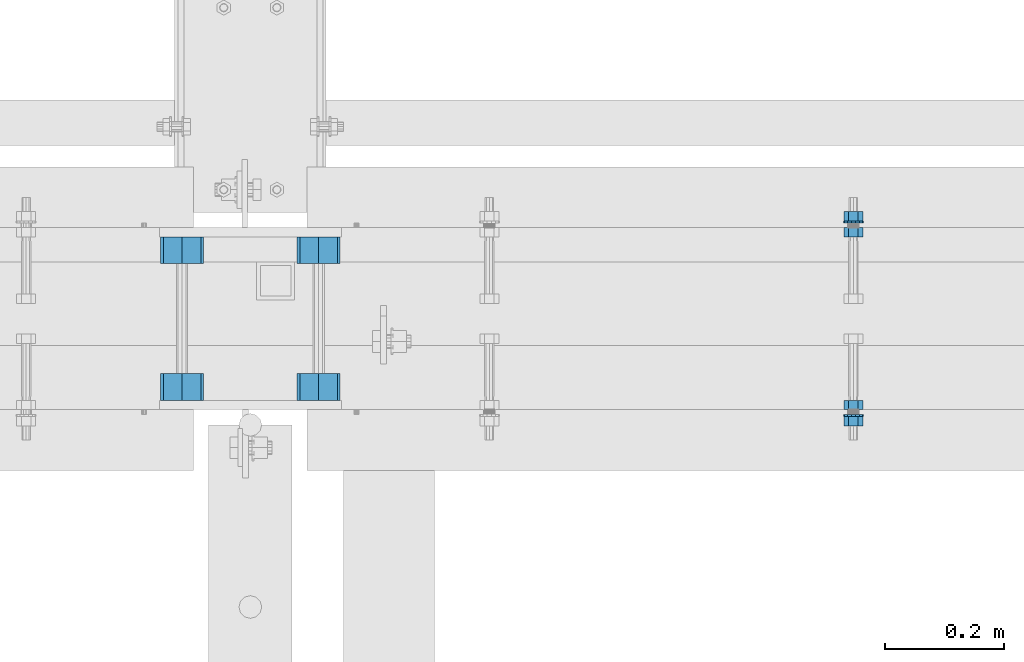
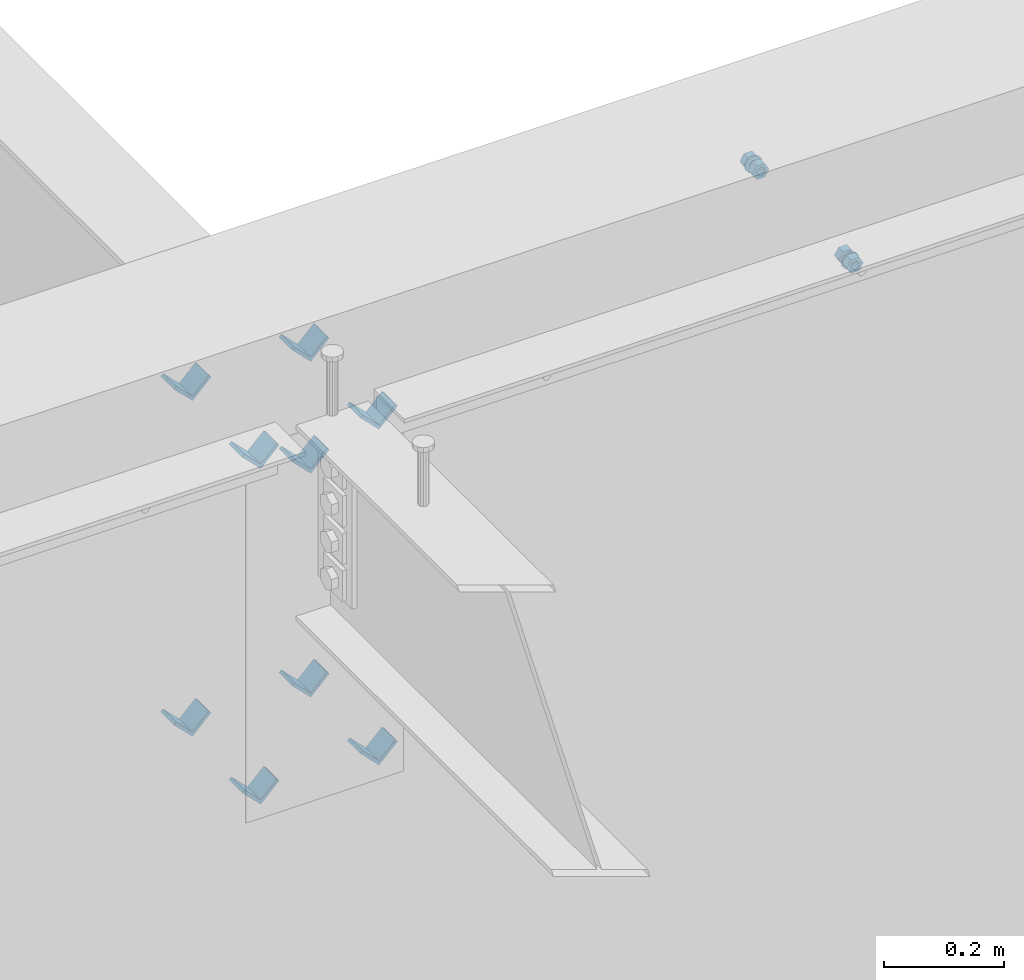
# One storey, part 610 of 975: 15 beams.
"""IFC2X3 building model written with IfcOpenShell, lengths in millimetres."""

from ifc_helpers import new_model, si_unit, frame, origin_with_axes, place, context, subcontext, project, spatial, faceted_brep, material, type_object, element, save


model = new_model("IFC2X3")

# Units and contexts
model_context = context("Model", 3, precision=1e-05, world=origin_with_axes())
body_context = subcontext(model_context, "Body", "Model", "MODEL_VIEW")
ifc_project = project(units=[si_unit("LENGTHUNIT", "METRE", prefix="MILLI"), si_unit("AREAUNIT", "SQUARE_METRE"), si_unit("VOLUMEUNIT", "CUBIC_METRE"), si_unit("MASSUNIT", "GRAM", prefix="KILO"), si_unit("TIMEUNIT", "SECOND"), si_unit("PLANEANGLEUNIT", "RADIAN"), si_unit("SOLIDANGLEUNIT", "STERADIAN"), si_unit("THERMODYNAMICTEMPERATUREUNIT", "DEGREE_CELSIUS"), si_unit("LUMINOUSINTENSITYUNIT", "LUMEN")], contexts=[model_context])

# Site, building, storey
site_placement = place(None, origin_with_axes())
site = spatial("IfcSite", under=ifc_project, at=site_placement, CompositionType="ELEMENT")
building_placement = place(site_placement, origin_with_axes())
building = spatial("IfcBuilding", under=site, at=building_placement, Name="Undefined", CompositionType="ELEMENT")
storey_placement = place(building_placement, origin_with_axes())
storey = spatial("IfcBuildingStorey", under=building, at=storey_placement, Name="Undefined", CompositionType="ELEMENT", Elevation=0.0)

# Beams
ifc_material = material(Name="STEEL/A36")
beam_type_1 = type_object("IfcBeamType", Name="L2X2X1/4", PredefinedType="NOTDEFINED")
for number, where, z_axis, x_axis, name in (
    (1, (8343.90041900943, 20688.3662709101, 3645.66996517217), (-0.707106781186557, 0.0, 0.707106781186538), (0.0, 1.0, 0.0), "ANGLE"),
    (2, (8115.3004190083, 20459.6337290899, 3188.4699651707), (-0.707106781186557, 0.0, 0.707106781186538), (0.0, 1.0, 0.0), "ANGLE"),
    (3, (8115.30041900943, 20459.6337290899, 3874.26996517217), (-0.707106781186557, 0.0, 0.707106781186538), (0.0, 1.0, 0.0), "ANGLE"),
    (4, (8343.90041900831, 20459.6337290899, 3188.4699651707), (-0.707106781186557, 0.0, 0.707106781186538), (0.0, 1.0, 0.0), "ANGLE"),
    (5, (8343.90041900943, 20459.6337290899, 3874.26996517217), (-0.707106781186557, 0.0, 0.707106781186538), (0.0, 1.0, 0.0), "ANGLE"),
    (6, (8115.3004190083, 20688.3662709101, 3188.4699651707), (-0.707106781186557, 0.0, 0.707106781186538), (0.0, 1.0, 0.0), "ANGLE"),
    (7, (8115.30041900943, 20688.3662709101, 3874.26996517217), (-0.707106781186557, 0.0, 0.707106781186538), (0.0, 1.0, 0.0), "ANGLE"),
    (8, (8343.90041900831, 20688.3662709101, 3188.4699651707), (-0.707106781186557, 0.0, 0.707106781186538), (0.0, 1.0, 0.0), "ANGLE"),
    (9, (8343.90041900943, 20688.3662709101, 3874.26996517217), (-0.707106781186557, 0.0, 0.707106781186538), (0.0, 1.0, 0.0), "ANGLE"),
):
    element("IfcBeam", number, at=place(storey_placement, frame(where, z_axis=z_axis, x_axis=x_axis)), inside=storey, type_object=beam_type_1, material=ifc_material, Name=name, ObjectType="L2X2X1/4", context=body_context, shape_type="Brep", body=[
        faceted_brep([(0.0, 25.3999999999724, -25.4000000000342), (0.0, 25.400000000016, 25.4000000000196), (44.4499999999971, 25.4000000000033, 25.4000000000051), (44.4499999999971, 25.4000000000033, -25.4000000000024), (3.27418092638254e-11, 19.0500000000002, 25.4000000000269), (44.4499999999971, 19.0500000000011, 25.400000000006), (-2.5465851649642e-11, 19.0500000000002, -19.0500000000211), (44.4499999999971, 19.0500000000011, -19.050000000002), (-2.5465851649642e-11, -25.3999999999996, -19.0500000000211), (44.4499999999971, -25.4000000000069, -19.0500000000038), (0.0, -25.400000000016, -25.4000000000196), (44.4499999999971, -25.4000000000069, -25.4000000000033)], [[[0, 1, 2, 3]], [[1, 4, 5, 2]], [[4, 6, 7, 5]], [[6, 8, 9, 7]], [[8, 10, 11, 9]], [[10, 0, 3, 11]], [[5, 7, 9, 11, 3, 2]], [[10, 8, 6, 4, 1, 0]]]),
    ])
beam_type_2 = type_object("IfcBeamType", Name="5/8_HEAVY_HEX_NUT", PredefinedType="NOTDEFINED")
beam_1_placement = place(storey_placement, frame((9239.24995116831, 20443.825, 3886.2), z_axis=(0.0, 0.0, -1.0), x_axis=(0.0, 1.0, 0.0)))
element("IfcBeam", 10, at=beam_1_placement, inside=storey, type_object=beam_type_2, material=ifc_material, Name="NUT", ObjectType="5/8_HEAVY_HEX_NUT", context=body_context, shape_type="Brep", body=[
    faceted_brep([(-1.09139364212751e-11, -15.8800001144436, -2.72848410531878e-12), (1.45519152283669e-11, -7.94000005722046, -13.7500000000036), (15.8750000000146, -7.94000005722137, -13.7500000000045), (15.8749999999891, -15.8800001144446, -2.72848410531878e-12), (2.91038304567337e-11, 7.94000005722319, -13.7500000000027), (15.8750000000291, 7.94000005722319, -13.7500000000027), (2.18278728425503e-11, 15.8800001144436, 9.09494701772928e-13), (15.8750000000218, 15.8800001144427, 9.09494701772928e-13), (-7.27595761418343e-12, 7.94000005722046, 13.7500000000027), (15.8749999999927, 7.94000005722046, 13.7500000000027), (-2.18278728425503e-11, -7.94000005722228, 13.7500000000009), (15.8749999999782, -7.94000005722319, 13.7500000000009), (-7.27595761418343e-12, 0.0, 8.72999954223724), (0.0, 3.78780484388062, 7.86545780435881), (15.875, 3.78780484387971, 7.86545780435881), (15.8749999999927, -9.09494701772928e-13, 8.72999954223724), (7.27595761418343e-12, 6.82538848405238, 5.44306568481716), (15.8750000000073, 6.82538848405238, 5.44306568481716), (1.09139364212751e-11, 8.51112022706275, 1.94260765157742), (15.8750000000109, 8.51112022706093, 1.94260765157651), (1.45519152283669e-11, 8.51112022706184, -1.94260765157651), (15.8750000000146, 8.51112022706184, -1.94260765157651), (2.18278728425503e-11, 6.8253884840542, -5.44306568481716), (15.8750000000218, 6.82538848405238, -5.44306568481716), (1.81898940354586e-11, 3.78780484388153, -7.86545780435881), (15.8750000000182, 3.78780484388062, -7.86545780435881), (1.81898940354586e-11, 9.09494701772928e-13, -8.72999954223997), (15.8750000000182, 9.09494701772928e-13, -8.72999954223997), (1.09139364212751e-11, -3.78780484387971, -7.86545780436063), (15.8750000000109, -3.78780484388062, -7.86545780436063), (3.63797880709171e-12, -6.82538848405238, -5.44306568481807), (15.8750000000036, -6.82538848405329, -5.44306568481807), (0.0, -8.51112022706184, -1.94260765157833), (15.875, -8.51112022706184, -1.94260765157833), (-7.27595761418343e-12, -8.51112022706184, 1.9426076515756), (15.8749999999927, -8.51112022706275, 1.9426076515756), (-1.09139364212751e-11, -6.82538848405329, 5.44306568481534), (15.8749999999927, -6.8253884840542, 5.44306568481534), (-7.27595761418343e-12, -3.78780484388062, 7.8654578043579), (15.8749999999927, -3.78780484388153, 7.8654578043579)], [[[0, 1, 2, 3]], [[1, 4, 5, 2]], [[4, 6, 7, 5]], [[6, 8, 9, 7]], [[8, 10, 11, 9]], [[10, 0, 3, 11]], [[12, 13, 14, 15]], [[13, 16, 17, 14]], [[16, 18, 19, 17]], [[18, 20, 21, 19]], [[20, 22, 23, 21]], [[22, 24, 25, 23]], [[24, 26, 27, 25]], [[26, 28, 29, 27]], [[28, 30, 31, 29]], [[30, 32, 33, 31]], [[32, 34, 35, 33]], [[34, 36, 37, 35]], [[36, 38, 39, 37]], [[38, 12, 15, 39]], [[5, 7, 9, 11, 3, 2], [17, 19, 21, 23, 25, 27, 29, 31, 33, 35, 37, 39, 15, 14]], [[10, 8, 6, 4, 1, 0], [38, 36, 34, 32, 30, 28, 26, 24, 22, 20, 18, 16, 13, 12]]]),
])
beam_2_placement = place(storey_placement, frame((9239.24995116831, 20748.6249996637, 3886.2), z_axis=(0.0, 0.0, 1.0), x_axis=(0.0, -1.0, 0.0)))
element("IfcBeam", 11, at=beam_2_placement, inside=storey, type_object=beam_type_2, material=ifc_material, Name="NUT", ObjectType="5/8_HEAVY_HEX_NUT", context=body_context, shape_type="Brep", body=[
    faceted_brep([(-1.09139364212751e-11, -15.8800001144436, -2.72848410531878e-12), (1.45519152283669e-11, -7.94000005722046, -13.7500000000036), (15.8750000000146, -7.94000005722137, -13.7500000000045), (15.8749999999891, -15.8800001144446, -2.72848410531878e-12), (2.91038304567337e-11, 7.94000005722319, -13.7500000000027), (15.8750000000291, 7.94000005722319, -13.7500000000027), (2.18278728425503e-11, 15.8800001144436, 9.09494701772928e-13), (15.8750000000218, 15.8800001144427, 9.09494701772928e-13), (-7.27595761418343e-12, 7.94000005722046, 13.7500000000027), (15.8749999999927, 7.94000005722046, 13.7500000000027), (-2.18278728425503e-11, -7.94000005722228, 13.7500000000009), (15.8749999999782, -7.94000005722319, 13.7500000000009), (-7.27595761418343e-12, 0.0, 8.72999954223724), (0.0, 3.78780484388062, 7.86545780435881), (15.875, 3.78780484387971, 7.86545780435881), (15.8749999999927, -9.09494701772928e-13, 8.72999954223724), (7.27595761418343e-12, 6.82538848405238, 5.44306568481716), (15.8750000000073, 6.82538848405238, 5.44306568481716), (1.09139364212751e-11, 8.51112022706275, 1.94260765157742), (15.8750000000109, 8.51112022706093, 1.94260765157651), (1.45519152283669e-11, 8.51112022706184, -1.94260765157651), (15.8750000000146, 8.51112022706184, -1.94260765157651), (2.18278728425503e-11, 6.8253884840542, -5.44306568481716), (15.8750000000218, 6.82538848405238, -5.44306568481716), (1.81898940354586e-11, 3.78780484388153, -7.86545780435881), (15.8750000000182, 3.78780484388062, -7.86545780435881), (1.81898940354586e-11, 9.09494701772928e-13, -8.72999954223997), (15.8750000000182, 9.09494701772928e-13, -8.72999954223997), (1.09139364212751e-11, -3.78780484387971, -7.86545780436063), (15.8750000000109, -3.78780484388062, -7.86545780436063), (3.63797880709171e-12, -6.82538848405238, -5.44306568481807), (15.8750000000036, -6.82538848405329, -5.44306568481807), (0.0, -8.51112022706184, -1.94260765157833), (15.875, -8.51112022706184, -1.94260765157833), (-7.27595761418343e-12, -8.51112022706184, 1.9426076515756), (15.8749999999927, -8.51112022706275, 1.9426076515756), (-1.09139364212751e-11, -6.82538848405329, 5.44306568481534), (15.8749999999927, -6.8253884840542, 5.44306568481534), (-7.27595761418343e-12, -3.78780484388062, 7.8654578043579), (15.8749999999927, -3.78780484388153, 7.8654578043579)], [[[0, 1, 2, 3]], [[1, 4, 5, 2]], [[4, 6, 7, 5]], [[6, 8, 9, 7]], [[8, 10, 11, 9]], [[10, 0, 3, 11]], [[12, 13, 14, 15]], [[13, 16, 17, 14]], [[16, 18, 19, 17]], [[18, 20, 21, 19]], [[20, 22, 23, 21]], [[22, 24, 25, 23]], [[24, 26, 27, 25]], [[26, 28, 29, 27]], [[28, 30, 31, 29]], [[30, 32, 33, 31]], [[32, 34, 35, 33]], [[34, 36, 37, 35]], [[36, 38, 39, 37]], [[38, 12, 15, 39]], [[5, 7, 9, 11, 3, 2], [17, 19, 21, 23, 25, 27, 29, 31, 33, 35, 37, 39, 15, 14]], [[10, 8, 6, 4, 1, 0], [38, 36, 34, 32, 30, 28, 26, 24, 22, 20, 18, 16, 13, 12]]]),
])
beam_3_placement = place(storey_placement, frame((9239.24995116833, 20775.6125, 3886.2), z_axis=(0.0, 0.0, 1.0), x_axis=(0.0, -1.0, 0.0)))
element("IfcBeam", 12, at=beam_3_placement, inside=storey, type_object=beam_type_2, material=ifc_material, Name="NUT", ObjectType="5/8_HEAVY_HEX_NUT", context=body_context, shape_type="Brep", body=[
    faceted_brep([(-1.09139364212751e-11, -15.8800001144436, -2.72848410531878e-12), (1.45519152283669e-11, -7.94000005722046, -13.7500000000036), (15.8750000000146, -7.94000005722137, -13.7500000000045), (15.8749999999891, -15.8800001144446, -2.72848410531878e-12), (2.91038304567337e-11, 7.94000005722319, -13.7500000000027), (15.8750000000291, 7.94000005722319, -13.7500000000027), (2.18278728425503e-11, 15.8800001144436, 9.09494701772928e-13), (15.8750000000218, 15.8800001144427, 9.09494701772928e-13), (-7.27595761418343e-12, 7.94000005722046, 13.7500000000027), (15.8749999999927, 7.94000005722046, 13.7500000000027), (-2.18278728425503e-11, -7.94000005722228, 13.7500000000009), (15.8749999999782, -7.94000005722319, 13.7500000000009), (-7.27595761418343e-12, 0.0, 8.72999954223724), (0.0, 3.78780484388062, 7.86545780435881), (15.875, 3.78780484387971, 7.86545780435881), (15.8749999999927, -9.09494701772928e-13, 8.72999954223724), (7.27595761418343e-12, 6.82538848405238, 5.44306568481716), (15.8750000000073, 6.82538848405238, 5.44306568481716), (1.09139364212751e-11, 8.51112022706275, 1.94260765157742), (15.8750000000109, 8.51112022706093, 1.94260765157651), (1.45519152283669e-11, 8.51112022706184, -1.94260765157651), (15.8750000000146, 8.51112022706184, -1.94260765157651), (2.18278728425503e-11, 6.8253884840542, -5.44306568481716), (15.8750000000218, 6.82538848405238, -5.44306568481716), (1.81898940354586e-11, 3.78780484388153, -7.86545780435881), (15.8750000000182, 3.78780484388062, -7.86545780435881), (1.81898940354586e-11, 9.09494701772928e-13, -8.72999954223997), (15.8750000000182, 9.09494701772928e-13, -8.72999954223997), (1.09139364212751e-11, -3.78780484387971, -7.86545780436063), (15.8750000000109, -3.78780484388062, -7.86545780436063), (3.63797880709171e-12, -6.82538848405238, -5.44306568481807), (15.8750000000036, -6.82538848405329, -5.44306568481807), (0.0, -8.51112022706184, -1.94260765157833), (15.875, -8.51112022706184, -1.94260765157833), (-7.27595761418343e-12, -8.51112022706184, 1.9426076515756), (15.8749999999927, -8.51112022706275, 1.9426076515756), (-1.09139364212751e-11, -6.82538848405329, 5.44306568481534), (15.8749999999927, -6.8253884840542, 5.44306568481534), (-7.27595761418343e-12, -3.78780484388062, 7.8654578043579), (15.8749999999927, -3.78780484388153, 7.8654578043579)], [[[0, 1, 2, 3]], [[1, 4, 5, 2]], [[4, 6, 7, 5]], [[6, 8, 9, 7]], [[8, 10, 11, 9]], [[10, 0, 3, 11]], [[12, 13, 14, 15]], [[13, 16, 17, 14]], [[16, 18, 19, 17]], [[18, 20, 21, 19]], [[20, 22, 23, 21]], [[22, 24, 25, 23]], [[24, 26, 27, 25]], [[26, 28, 29, 27]], [[28, 30, 31, 29]], [[30, 32, 33, 31]], [[32, 34, 35, 33]], [[34, 36, 37, 35]], [[36, 38, 39, 37]], [[38, 12, 15, 39]], [[5, 7, 9, 11, 3, 2], [17, 19, 21, 23, 25, 27, 29, 31, 33, 35, 37, 39, 15, 14]], [[10, 8, 6, 4, 1, 0], [38, 36, 34, 32, 30, 28, 26, 24, 22, 20, 18, 16, 13, 12]]]),
])
beam_4_placement = place(storey_placement, frame((9239.24995116833, 20416.8375, 3886.2), z_axis=(0.0, 0.0, -1.0), x_axis=(0.0, 1.0, 0.0)))
element("IfcBeam", 13, at=beam_4_placement, inside=storey, type_object=beam_type_2, material=ifc_material, Name="NUT", ObjectType="5/8_HEAVY_HEX_NUT", context=body_context, shape_type="Brep", body=[
    faceted_brep([(-1.09139364212751e-11, -15.8800001144436, -2.72848410531878e-12), (1.45519152283669e-11, -7.94000005722046, -13.7500000000036), (15.8750000000146, -7.94000005722137, -13.7500000000045), (15.8749999999891, -15.8800001144446, -2.72848410531878e-12), (2.91038304567337e-11, 7.94000005722319, -13.7500000000027), (15.8750000000291, 7.94000005722319, -13.7500000000027), (2.18278728425503e-11, 15.8800001144436, 9.09494701772928e-13), (15.8750000000218, 15.8800001144427, 9.09494701772928e-13), (-7.27595761418343e-12, 7.94000005722046, 13.7500000000027), (15.8749999999927, 7.94000005722046, 13.7500000000027), (-2.18278728425503e-11, -7.94000005722228, 13.7500000000009), (15.8749999999782, -7.94000005722319, 13.7500000000009), (-7.27595761418343e-12, 0.0, 8.72999954223724), (0.0, 3.78780484388062, 7.86545780435881), (15.875, 3.78780484387971, 7.86545780435881), (15.8749999999927, -9.09494701772928e-13, 8.72999954223724), (7.27595761418343e-12, 6.82538848405238, 5.44306568481716), (15.8750000000073, 6.82538848405238, 5.44306568481716), (1.09139364212751e-11, 8.51112022706275, 1.94260765157742), (15.8750000000109, 8.51112022706093, 1.94260765157651), (1.45519152283669e-11, 8.51112022706184, -1.94260765157651), (15.8750000000146, 8.51112022706184, -1.94260765157651), (2.18278728425503e-11, 6.8253884840542, -5.44306568481716), (15.8750000000218, 6.82538848405238, -5.44306568481716), (1.81898940354586e-11, 3.78780484388153, -7.86545780435881), (15.8750000000182, 3.78780484388062, -7.86545780435881), (1.81898940354586e-11, 9.09494701772928e-13, -8.72999954223997), (15.8750000000182, 9.09494701772928e-13, -8.72999954223997), (1.09139364212751e-11, -3.78780484387971, -7.86545780436063), (15.8750000000109, -3.78780484388062, -7.86545780436063), (3.63797880709171e-12, -6.82538848405238, -5.44306568481807), (15.8750000000036, -6.82538848405329, -5.44306568481807), (0.0, -8.51112022706184, -1.94260765157833), (15.875, -8.51112022706184, -1.94260765157833), (-7.27595761418343e-12, -8.51112022706184, 1.9426076515756), (15.8749999999927, -8.51112022706275, 1.9426076515756), (-1.09139364212751e-11, -6.82538848405329, 5.44306568481534), (15.8749999999927, -6.8253884840542, 5.44306568481534), (-7.27595761418343e-12, -3.78780484388062, 7.8654578043579), (15.8749999999927, -3.78780484388153, 7.8654578043579)], [[[0, 1, 2, 3]], [[1, 4, 5, 2]], [[4, 6, 7, 5]], [[6, 8, 9, 7]], [[8, 10, 11, 9]], [[10, 0, 3, 11]], [[12, 13, 14, 15]], [[13, 16, 17, 14]], [[16, 18, 19, 17]], [[18, 20, 21, 19]], [[20, 22, 23, 21]], [[22, 24, 25, 23]], [[24, 26, 27, 25]], [[26, 28, 29, 27]], [[28, 30, 31, 29]], [[30, 32, 33, 31]], [[32, 34, 35, 33]], [[34, 36, 37, 35]], [[36, 38, 39, 37]], [[38, 12, 15, 39]], [[5, 7, 9, 11, 3, 2], [17, 19, 21, 23, 25, 27, 29, 31, 33, 35, 37, 39, 15, 14]], [[10, 8, 6, 4, 1, 0], [38, 36, 34, 32, 30, 28, 26, 24, 22, 20, 18, 16, 13, 12]]]),
])
beam_type_3 = type_object("IfcBeamType", Name="5/8_WASHER", PredefinedType="NOTDEFINED")
beam_5_placement = place(storey_placement, frame((9239.24995116837, 20759.7375, 3886.2), z_axis=(0.0, 0.0, 1.0), x_axis=(0.0, -1.0, 0.0)))
element("IfcBeam", 14, at=beam_5_placement, inside=storey, type_object=beam_type_3, material=ifc_material, Name="WASHER", ObjectType="5/8_WASHER", context=body_context, shape_type="Brep", body=[
    faceted_brep([(1.09139364212751e-11, -16.670000076293, -2.72848410531878e-12), (2.18278728425503e-11, -15.0191510966704, -7.23284196419536), (3.1750000000211, -15.0191510966711, -7.23284196419627), (3.17500000001019, -16.6700000762937, -1.81898940354586e-12), (2.91038304567337e-11, -10.3935750445523, -13.0331308723944), (3.17500000002838, -10.3935750445526, -13.0331308723953), (2.91038304567337e-11, -3.70942398602756, -16.2520483704566), (3.17500000002838, -3.70942398602779, -16.2520483704566), (2.5465851649642e-11, 3.70942398602961, -16.2520483704557), (3.17500000002474, 3.70942398602961, -16.2520483704566), (1.45519152283669e-11, 10.3935750445542, -13.0331308723935), (3.17500000001382, 10.3935750445537, -13.0331308723944), (0.0, 15.0191510966717, -7.23284196419354), (3.17499999999927, 15.0191510966713, -7.23284196419354), (-7.27595761418343e-12, 16.6700000762933, 0.0), (3.174999999992, 16.6700000762928, -9.09494701772928e-13), (-1.81898940354586e-11, 15.0191510966706, 7.23284196419354), (3.17499999998108, 15.0191510966704, 7.23284196419354), (-2.5465851649642e-11, 10.3935750445519, 13.0331308723926), (3.17499999997381, 10.3935750445517, 13.0331308723926), (-2.5465851649642e-11, 3.70942398602733, 16.2520483704538), (3.17499999997381, 3.7094239860271, 16.2520483704529), (-2.18278728425503e-11, -3.70942398602983, 16.2520483704529), (3.17499999997744, -3.70942398603006, 16.2520483704538), (-1.09139364212751e-11, -10.3935750445542, 13.0331308723908), (3.17499999998836, -10.3935750445544, 13.0331308723908), (0.0, -15.0191510966717, 7.23284196419172), (3.17499999999927, -15.019151096672, 7.23284196419081), (-7.27595761418343e-12, 0.0, 8.72999954223724), (0.0, 3.78780484388062, 7.86545780435881), (3.17499999998472, 3.78780484387903, 7.86545780435699), (3.17499999998836, -9.09494701772928e-13, 8.72999954223542), (7.27595761418343e-12, 6.82538848405238, 5.44306568481716), (3.17499999998836, 6.82538848405102, 5.44306568481534), (1.09139364212751e-11, 8.51112022706275, 1.94260765157742), (3.174999999992, 8.51112022705979, 1.94260765157651), (1.45519152283669e-11, 8.51112022706184, -1.94260765157651), (3.17499999999563, 8.51112022706025, -1.94260765157742), (2.18278728425503e-11, 6.8253884840542, -5.44306568481716), (3.17500000000655, 6.8253884840517, -5.44306568481807), (1.81898940354586e-11, 3.78780484388153, -7.86545780435881), (3.17500000001019, 3.78780484388017, -7.86545780435972), (1.81898940354586e-11, 9.09494701772928e-13, -8.72999954223997), (3.17500000001382, 6.82121026329696e-13, -8.72999954223997), (1.09139364212751e-11, -3.78780484387971, -7.86545780436063), (3.17500000001382, -3.78780484387994, -7.86545780436063), (3.63797880709171e-12, -6.82538848405238, -5.44306568481807), (3.17500000001019, -6.82538848405147, -5.44306568481898), (0.0, -8.51112022706184, -1.94260765157833), (3.17500000001019, -8.5111202270607, -1.94260765157924), (-7.27595761418343e-12, -8.51112022706184, 1.9426076515756), (3.17500000000291, -8.51112022706093, 1.94260765157469), (-1.09139364212751e-11, -6.82538848405329, 5.44306568481534), (3.17499999999563, -6.82538848405238, 5.44306568481534), (-7.27595761418343e-12, -3.78780484388062, 7.8654578043579), (3.174999999992, -3.78780484388085, 7.86545780435699)], [[[0, 1, 2, 3]], [[1, 4, 5, 2]], [[4, 6, 7, 5]], [[6, 8, 9, 7]], [[8, 10, 11, 9]], [[10, 12, 13, 11]], [[12, 14, 15, 13]], [[14, 16, 17, 15]], [[16, 18, 19, 17]], [[18, 20, 21, 19]], [[20, 22, 23, 21]], [[22, 24, 25, 23]], [[24, 26, 27, 25]], [[26, 0, 3, 27]], [[28, 29, 30, 31]], [[29, 32, 33, 30]], [[32, 34, 35, 33]], [[34, 36, 37, 35]], [[36, 38, 39, 37]], [[38, 40, 41, 39]], [[40, 42, 43, 41]], [[42, 44, 45, 43]], [[44, 46, 47, 45]], [[46, 48, 49, 47]], [[48, 50, 51, 49]], [[50, 52, 53, 51]], [[52, 54, 55, 53]], [[54, 28, 31, 55]], [[5, 7, 9, 11, 13, 15, 17, 19, 21, 23, 25, 27, 3, 2], [33, 35, 37, 39, 41, 43, 45, 47, 49, 51, 53, 55, 31, 30]], [[26, 24, 22, 20, 18, 16, 14, 12, 10, 8, 6, 4, 1, 0], [54, 52, 50, 48, 46, 44, 42, 40, 38, 36, 34, 32, 29, 28]]]),
])
beam_6_placement = place(storey_placement, frame((9239.24995116837, 20432.7125, 3886.2), z_axis=(0.0, 0.0, -1.0), x_axis=(0.0, 1.0, 0.0)))
element("IfcBeam", 15, at=beam_6_placement, inside=storey, type_object=beam_type_3, material=ifc_material, Name="WASHER", ObjectType="5/8_WASHER", context=body_context, shape_type="Brep", body=[
    faceted_brep([(1.09139364212751e-11, -16.670000076293, -2.72848410531878e-12), (2.18278728425503e-11, -15.0191510966704, -7.23284196419536), (3.1750000000211, -15.0191510966711, -7.23284196419627), (3.17500000001019, -16.6700000762937, -1.81898940354586e-12), (2.91038304567337e-11, -10.3935750445523, -13.0331308723944), (3.17500000002838, -10.3935750445526, -13.0331308723953), (2.91038304567337e-11, -3.70942398602756, -16.2520483704566), (3.17500000002838, -3.70942398602779, -16.2520483704566), (2.5465851649642e-11, 3.70942398602961, -16.2520483704557), (3.17500000002474, 3.70942398602961, -16.2520483704566), (1.45519152283669e-11, 10.3935750445542, -13.0331308723935), (3.17500000001382, 10.3935750445537, -13.0331308723944), (0.0, 15.0191510966717, -7.23284196419354), (3.17499999999927, 15.0191510966713, -7.23284196419354), (-7.27595761418343e-12, 16.6700000762933, 0.0), (3.174999999992, 16.6700000762928, -9.09494701772928e-13), (-1.81898940354586e-11, 15.0191510966706, 7.23284196419354), (3.17499999998108, 15.0191510966704, 7.23284196419354), (-2.5465851649642e-11, 10.3935750445519, 13.0331308723926), (3.17499999997381, 10.3935750445517, 13.0331308723926), (-2.5465851649642e-11, 3.70942398602733, 16.2520483704538), (3.17499999997381, 3.7094239860271, 16.2520483704529), (-2.18278728425503e-11, -3.70942398602983, 16.2520483704529), (3.17499999997744, -3.70942398603006, 16.2520483704538), (-1.09139364212751e-11, -10.3935750445542, 13.0331308723908), (3.17499999998836, -10.3935750445544, 13.0331308723908), (0.0, -15.0191510966717, 7.23284196419172), (3.17499999999927, -15.019151096672, 7.23284196419081), (-7.27595761418343e-12, 0.0, 8.72999954223724), (0.0, 3.78780484388062, 7.86545780435881), (3.17499999998472, 3.78780484387903, 7.86545780435699), (3.17499999998836, -9.09494701772928e-13, 8.72999954223542), (7.27595761418343e-12, 6.82538848405238, 5.44306568481716), (3.17499999998836, 6.82538848405102, 5.44306568481534), (1.09139364212751e-11, 8.51112022706275, 1.94260765157742), (3.174999999992, 8.51112022705979, 1.94260765157651), (1.45519152283669e-11, 8.51112022706184, -1.94260765157651), (3.17499999999563, 8.51112022706025, -1.94260765157742), (2.18278728425503e-11, 6.8253884840542, -5.44306568481716), (3.17500000000655, 6.8253884840517, -5.44306568481807), (1.81898940354586e-11, 3.78780484388153, -7.86545780435881), (3.17500000001019, 3.78780484388017, -7.86545780435972), (1.81898940354586e-11, 9.09494701772928e-13, -8.72999954223997), (3.17500000001382, 6.82121026329696e-13, -8.72999954223997), (1.09139364212751e-11, -3.78780484387971, -7.86545780436063), (3.17500000001382, -3.78780484387994, -7.86545780436063), (3.63797880709171e-12, -6.82538848405238, -5.44306568481807), (3.17500000001019, -6.82538848405147, -5.44306568481898), (0.0, -8.51112022706184, -1.94260765157833), (3.17500000001019, -8.5111202270607, -1.94260765157924), (-7.27595761418343e-12, -8.51112022706184, 1.9426076515756), (3.17500000000291, -8.51112022706093, 1.94260765157469), (-1.09139364212751e-11, -6.82538848405329, 5.44306568481534), (3.17499999999563, -6.82538848405238, 5.44306568481534), (-7.27595761418343e-12, -3.78780484388062, 7.8654578043579), (3.174999999992, -3.78780484388085, 7.86545780435699)], [[[0, 1, 2, 3]], [[1, 4, 5, 2]], [[4, 6, 7, 5]], [[6, 8, 9, 7]], [[8, 10, 11, 9]], [[10, 12, 13, 11]], [[12, 14, 15, 13]], [[14, 16, 17, 15]], [[16, 18, 19, 17]], [[18, 20, 21, 19]], [[20, 22, 23, 21]], [[22, 24, 25, 23]], [[24, 26, 27, 25]], [[26, 0, 3, 27]], [[28, 29, 30, 31]], [[29, 32, 33, 30]], [[32, 34, 35, 33]], [[34, 36, 37, 35]], [[36, 38, 39, 37]], [[38, 40, 41, 39]], [[40, 42, 43, 41]], [[42, 44, 45, 43]], [[44, 46, 47, 45]], [[46, 48, 49, 47]], [[48, 50, 51, 49]], [[50, 52, 53, 51]], [[52, 54, 55, 53]], [[54, 28, 31, 55]], [[5, 7, 9, 11, 13, 15, 17, 19, 21, 23, 25, 27, 3, 2], [33, 35, 37, 39, 41, 43, 45, 47, 49, 51, 53, 55, 31, 30]], [[26, 24, 22, 20, 18, 16, 14, 12, 10, 8, 6, 4, 1, 0], [54, 52, 50, 48, 46, 44, 42, 40, 38, 36, 34, 32, 29, 28]]]),
])

save(model, "model.ifc")
